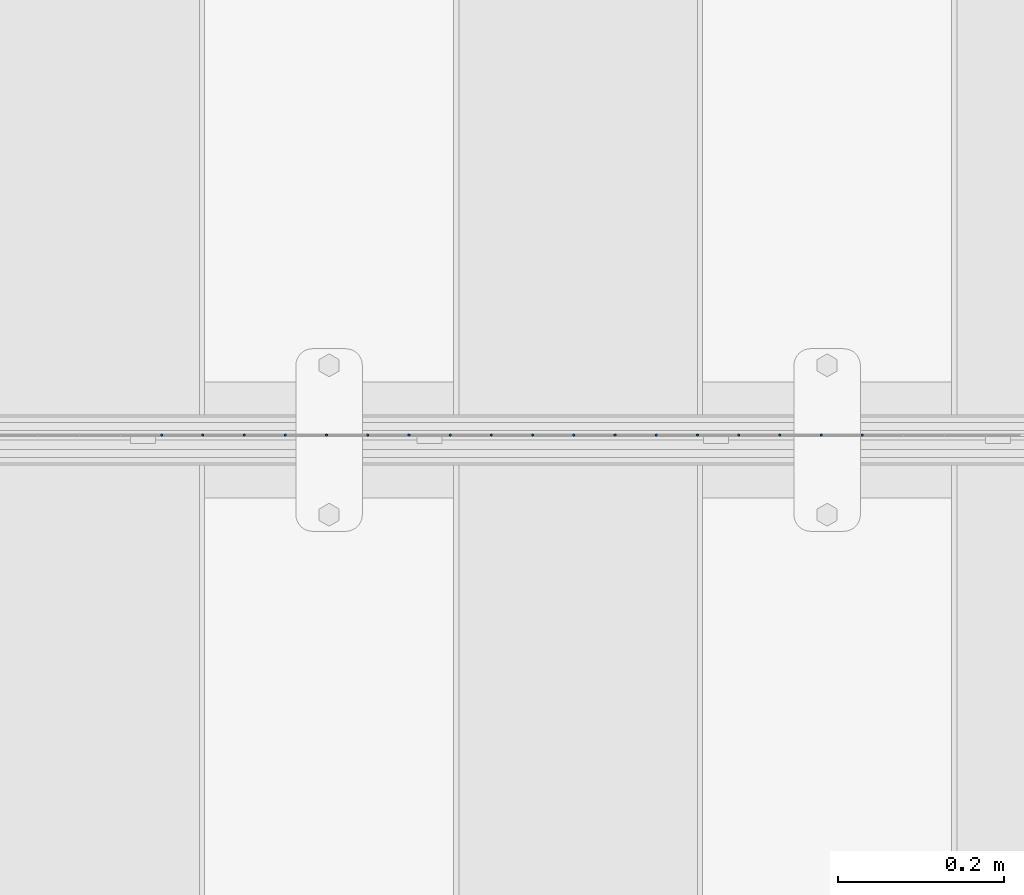
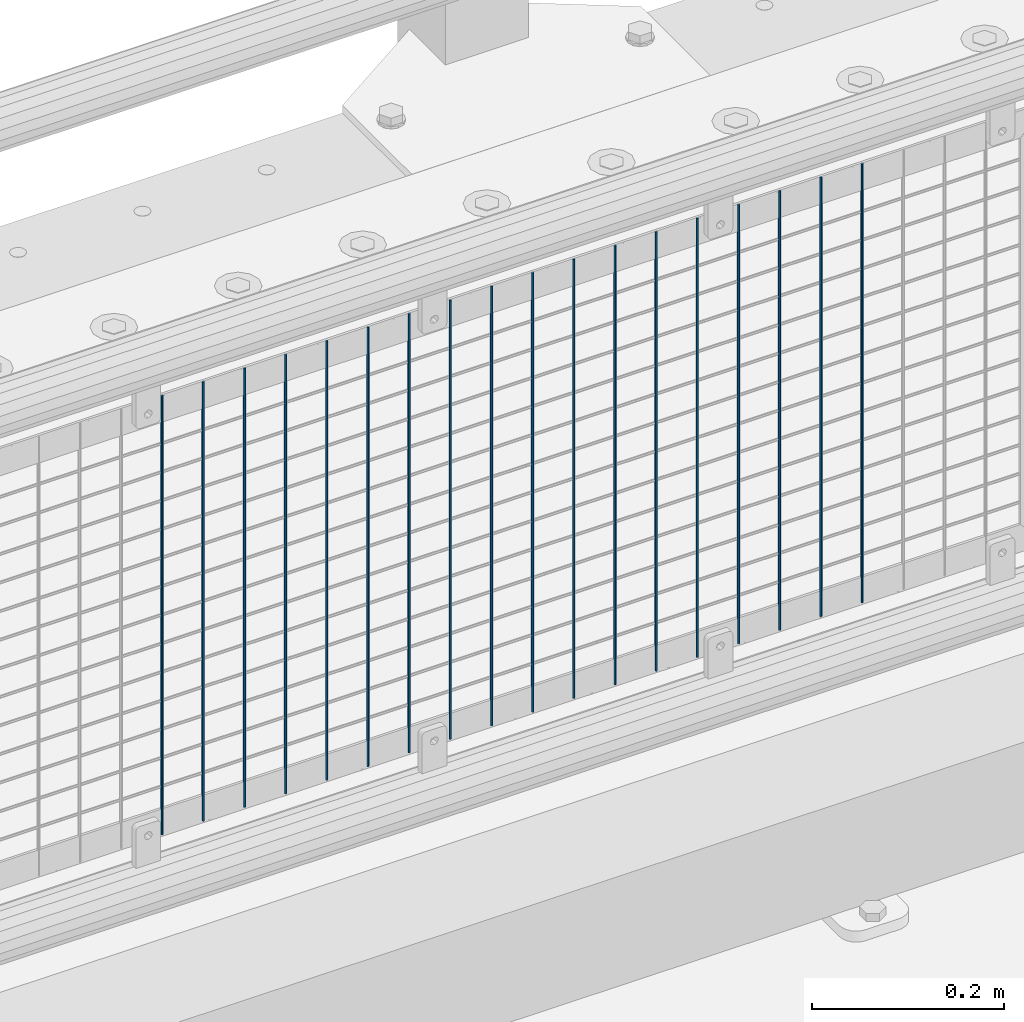
# One storey, part 55 of 208: 18 columns.
"""IFC2X3 building model written with IfcOpenShell, lengths in millimetres."""

from ifc_helpers import new_model, si_unit, frame, origin_with_axes, place, context, subcontext, project, spatial, faceted_brep, material, type_object, element, save


model = new_model("IFC2X3")

# Units and contexts
model_context = context("Model", 3, precision=1e-05, world=origin_with_axes())
body_context = subcontext(model_context, "Body", "Model", "MODEL_VIEW")
ifc_project = project(units=[si_unit("LENGTHUNIT", "METRE", prefix="MILLI"), si_unit("AREAUNIT", "SQUARE_METRE"), si_unit("VOLUMEUNIT", "CUBIC_METRE"), si_unit("MASSUNIT", "GRAM", prefix="KILO"), si_unit("TIMEUNIT", "SECOND"), si_unit("PLANEANGLEUNIT", "RADIAN"), si_unit("SOLIDANGLEUNIT", "STERADIAN"), si_unit("THERMODYNAMICTEMPERATUREUNIT", "DEGREE_CELSIUS"), si_unit("LUMINOUSINTENSITYUNIT", "LUMEN")], contexts=[model_context])

# Site, building, storey
site_placement = place(None, origin_with_axes())
site = spatial("IfcSite", under=ifc_project, at=site_placement, CompositionType="ELEMENT")
building_placement = place(site_placement, origin_with_axes())
building = spatial("IfcBuilding", under=site, at=building_placement, Name="Standard", CompositionType="ELEMENT")
storey_placement = place(building_placement, origin_with_axes())
storey = spatial("IfcBuildingStorey", under=building, at=storey_placement, Name="Undefined", CompositionType="ELEMENT", Elevation=0.0)

# Columns
ifc_material = material(Name="Misc_Undefined")
column_type = type_object("IfcColumnType", Name="D3", PredefinedType="NOTDEFINED")
for number, where, z_axis, x_axis in (
    (1, (-40507.625, 4670.5, 353.02), (-1.0, 0.0, 0.0), (0.0, 0.0, 1.0)),
    (2, (-40557.28, 4670.5, 353.02), (-1.0, 0.0, 0.0), (0.0, 0.0, 1.0)),
    (3, (-40606.935, 4670.5, 353.02), (-1.0, 0.0, 0.0), (0.0, 0.0, 1.0)),
    (4, (-40656.59, 4670.5, 353.02), (-1.0, 0.0, 0.0), (0.0, 0.0, 1.0)),
    (5, (-40706.245, 4670.5, 353.02), (-1.0, 0.0, 0.0), (0.0, 0.0, 1.0)),
    (6, (-40755.9, 4670.5, 353.02), (-1.0, 0.0, 0.0), (0.0, 0.0, 1.0)),
    (7, (-40805.555, 4670.5, 353.02), (-1.0, 0.0, 0.0), (0.0, 0.0, 1.0)),
    (8, (-40855.21, 4670.5, 353.02), (-1.0, 0.0, 0.0), (0.0, 0.0, 1.0)),
    (9, (-40904.865, 4670.5, 353.02), (-1.0, 0.0, 0.0), (0.0, 0.0, 1.0)),
    (10, (-40954.52, 4670.5, 353.02), (-1.0, 0.0, 0.0), (0.0, 0.0, 1.0)),
    (11, (-41004.175, 4670.5, 353.02), (-1.0, 0.0, 0.0), (0.0, 0.0, 1.0)),
    (12, (-41053.83, 4670.5, 353.02), (-1.0, 0.0, 0.0), (0.0, 0.0, 1.0)),
    (13, (-41103.485, 4670.5, 353.02), (-1.0, 0.0, 0.0), (0.0, 0.0, 1.0)),
    (14, (-41153.14, 4670.5, 353.02), (-1.0, 0.0, 0.0), (0.0, 0.0, 1.0)),
    (15, (-41202.795, 4670.5, 353.02), (-1.0, 0.0, 0.0), (0.0, 0.0, 1.0)),
    (16, (-41252.45, 4670.5, 353.02), (-1.0, 0.0, 0.0), (0.0, 0.0, 1.0)),
    (17, (-41302.105, 4670.5, 353.02), (-1.0, 0.0, 0.0), (0.0, 0.0, 1.0)),
    (18, (-41351.76, 4670.5, 353.02), (-1.0, 0.0, 0.0), (0.0, 0.0, 1.0)),
):
    element("IfcColumn", number, at=place(storey_placement, frame(where, z_axis=z_axis, x_axis=x_axis)), inside=storey, type_object=column_type, material=ifc_material, ObjectType="D3", context=body_context, shape_type="Brep", body=[
        faceted_brep([(0.0, -1.49999999999909, 3.63797880709171e-12), (-7.27595761418343e-12, -0.749999999999091, -1.29903810567669), (560.0, -0.75, -1.29903810567703), (560.0, -1.5, 0.0), (-3.63797880709171e-12, 0.750000000000909, -1.29903810567669), (560.0, 0.75, -1.29903810567703), (0.0, 1.50000000000182, 3.63797880709171e-12), (560.0, 1.5, 0.0), (-3.63797880709171e-12, 0.750000000000909, 1.29903810567669), (560.0, 0.75, 1.29903810567703), (-7.27595761418343e-12, -0.749999999999091, 1.29903810567669), (560.0, -0.75, 1.29903810567703)], [[[0, 1, 2, 3]], [[1, 4, 5, 2]], [[4, 6, 7, 5]], [[6, 8, 9, 7]], [[8, 10, 11, 9]], [[10, 0, 3, 11]], [[5, 7, 9, 11, 3, 2]], [[10, 8, 6, 4, 1, 0]]]),
    ])

save(model, "model.ifc")
